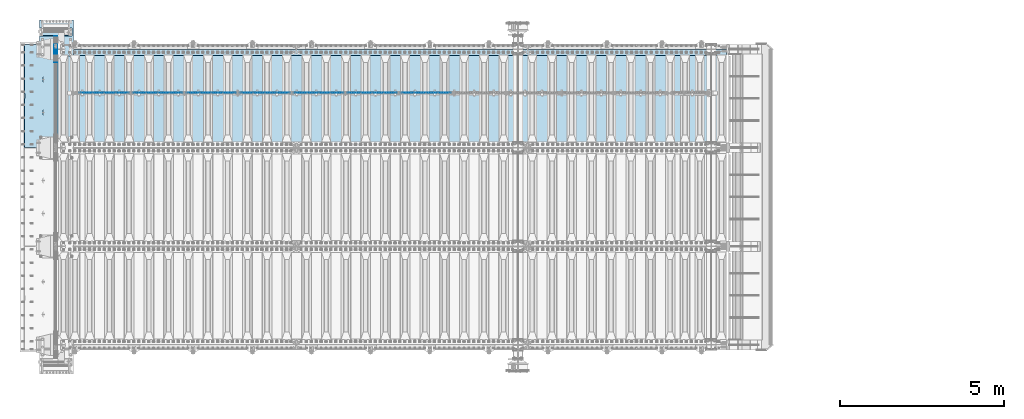
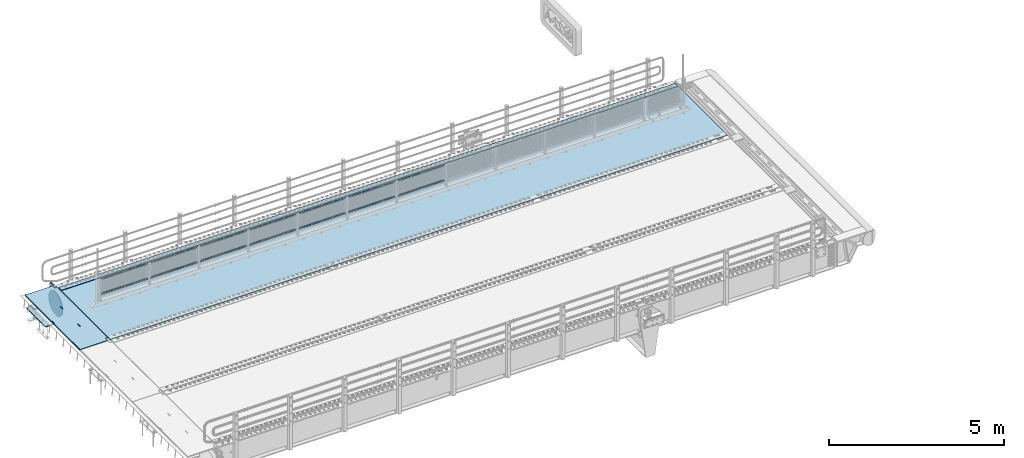
# One storey, part 212 of 270: 21 plates.
"""IFC2X3 building model written with IfcOpenShell, lengths in millimetres."""

from ifc_helpers import new_model, si_unit, frame, origin_with_axes, place, context, subcontext, project, spatial, faceted_brep, material, type_object, element, save


model = new_model("IFC2X3")

# Units and contexts
model_context = context("Model", 3, precision=1e-05, world=origin_with_axes())
body_context = subcontext(model_context, "Body", "Model", "MODEL_VIEW")
ifc_project = project(units=[si_unit("LENGTHUNIT", "METRE", prefix="MILLI"), si_unit("AREAUNIT", "SQUARE_METRE"), si_unit("VOLUMEUNIT", "CUBIC_METRE"), si_unit("MASSUNIT", "GRAM", prefix="KILO"), si_unit("TIMEUNIT", "SECOND"), si_unit("PLANEANGLEUNIT", "RADIAN"), si_unit("SOLIDANGLEUNIT", "STERADIAN"), si_unit("THERMODYNAMICTEMPERATUREUNIT", "DEGREE_CELSIUS"), si_unit("LUMINOUSINTENSITYUNIT", "LUMEN")], contexts=[model_context])

# Site, building, storey
site_placement = place(None, origin_with_axes())
site = spatial("IfcSite", under=ifc_project, at=site_placement, CompositionType="ELEMENT")
building_placement = place(site_placement, origin_with_axes())
building = spatial("IfcBuilding", under=site, at=building_placement, Name="Standard", CompositionType="ELEMENT")
storey_placement = place(building_placement, origin_with_axes())
storey = spatial("IfcBuildingStorey", under=building, at=storey_placement, Name="Undefined", CompositionType="ELEMENT", Elevation=0.0)

# Plates
ifc_material_1 = material(Name="STEEL/S355N")
plate_type_1 = type_object("IfcPlateType", PredefinedType="NOTDEFINED")
plate_1_placement = place(storey_placement, frame((-5.0037545708802, -14850.0000738707, -0.984391683369125), z_axis=(0.0, -0.999999999987744, -4.95099999993769e-06), x_axis=(-0.999999999879068, -1.00000022172504e-09, -1.55519999981193e-05)))
element("IfcPlate", 1, at=plate_1_placement, inside=storey, type_object=plate_type_1, material=ifc_material_1, context=body_context, shape_type="Brep", body=[
    faceted_brep([(14.9998601691701, 15.0, 125.000024820878), (-0.000294611402146039, -0.000806902969057388, 124.999936248681), (-0.00191941583158783, 0.000806844427335363, 3020.00000492307), (14.9966216875132, 15.0, 3020.00007976655), (999.996459960937, 5.0, 3.63797880709171e-12), (984.996459960937, 15.0, 3.63797880709171e-12), (984.996459718778, 15.0, 3145.0), (999.996459718778, 5.0, 3145.0), (984.996459961366, -15.0, 0.0), (999.996459960937, -5.0, 3.63797880709171e-12), (999.996459718778, -5.0, 3145.0), (984.996459719206, -15.0, 3145.0), (74.9997820614451, -15.0, 0.0), (74.9996421865538, -15.0000000127077, 124.999930084148), (75.0001087165527, 15.0, 125.000079754147), (75.0002485914438, 15.0, 0.0), (-0.000449375328801516, -14.9999999951864, 124.999861417793), (395.486056604085, -15.0000000067239, 2004.40983005394), (395.486056604084, 15.0, 2004.40983005394), (394.996621766798, 15.0, 2007.4999999977), (394.996621766798, -15.0000000067363, 2007.4999999977), (396.906451823501, -15.0000000066914, 2001.62214747477), (396.906451823501, 15.0, 2001.62214747477), (399.118769244497, -15.0000000066418, 1999.40983005394), (399.118769244497, 15.0, 1999.40983005394), (401.906451823781, -15.0000000065801, 1997.98943483475), (401.906451823781, 15.0, 1997.98943483474), (404.996621767569, -15.0000000065123, 1997.4999999977), (404.996621767569, 15.0, 1997.49999999769), (408.086791711164, -15.0000000064451, 1997.98943483474), (408.086791711164, 15.0, 1997.98943483474), (410.874474290229, -15.0000000063849, 1999.40983005394), (410.874474290229, 15.0, 1999.40983005394), (413.086791710883, -15.0000000063378, 2001.62214747477), (413.086791710883, 15.0, 2001.62214747477), (414.507186929871, -15.0000000063082, 2004.40983005394), (414.507186929871, 15.0, 2004.40983005394), (414.996621766684, -15.0000000062992, 2007.49999999769), (414.996621766684, 15.0, 2007.49999999769), (414.99662175677, -15.0000000063698, 2137.49999999769), (414.99662175677, 15.0, 2137.49999999769), (414.507186919485, -15.0000000063821, 2140.59016994144), (414.507186919485, 15.0, 2140.59016994144), (413.086791700069, -15.0000000064147, 2143.37785252062), (413.086791700069, 15.0, 2143.37785252061), (410.874474279073, -15.0000000064642, 2145.59016994145), (410.874474279073, 15.0, 2145.59016994144), (408.086791699787, -15.0000000065259, 2147.01056516065), (408.086791699787, 15.0, 2147.01056516065), (404.996621755999, -15.0000000065937, 2147.49999999769), (404.996621755999, 15.0, 2147.49999999769), (401.906451812295, -15.000000006661, 2147.01056516065), (401.906451812295, 15.0, 2147.01056516065), (399.118769233229, -15.0000000067211, 2145.59016994145), (399.118769233229, 15.0, 2145.59016994145), (396.906451812575, -15.0000000067683, 2143.37785252062), (396.906451812575, 15.0, 2143.37785252062), (395.486056593588, -15.0000000067978, 2140.59016994145), (395.486056593588, 15.0, 2140.59016994144), (394.996621756778, -15.0000000068068, 2137.4999999977), (394.996621756778, 15.0, 2137.4999999977), (960.486056642586, -14.9999999941054, 1504.40983005418), (960.486056642586, 15.0, 1504.40983005418), (959.996621805299, 15.0, 1507.49999999792), (959.996621805299, -14.9999999941178, 1507.49999999793), (961.906451862003, -14.9999999940729, 1501.622147475), (961.906451862003, 15.0, 1501.622147475), (964.118769282998, -14.9999999940233, 1499.40983005418), (964.118769282998, 15.0, 1499.40983005418), (966.906451862283, -14.9999999939616, 1497.98943483498), (966.906451862283, 15.0, 1497.98943483497), (969.99662180607, -14.9999999938938, 1497.49999999793), (969.99662180607, 15.0, 1497.49999999793), (973.086791749665, -14.9999999938266, 1497.98943483497), (973.086791749666, 15.0, 1497.98943483497), (975.87447432873, -14.9999999937664, 1499.40983005418), (975.87447432873, 15.0, 1499.40983005418), (978.086791749384, -14.9999999937193, 1501.622147475), (978.086791749384, 15.0, 1501.622147475), (979.507186968372, -14.9999999936897, 1504.40983005417), (979.507186968372, 15.0, 1504.40983005417), (979.996621805185, -14.9999999936807, 1507.49999999792), (979.996621805184, 15.0, 1507.49999999792), (979.996621795271, -14.9999999937513, 1637.49999999792), (979.996621795271, 15.0, 1637.49999999792), (979.507186957986, -14.9999999937636, 1640.59016994167), (979.507186957986, 15.0, 1640.59016994167), (978.08679173857, -14.9999999937962, 1643.37785252085), (978.08679173857, 15.0, 1643.37785252085), (975.874474317574, -14.9999999938457, 1645.59016994168), (975.874474317574, 15.0, 1645.59016994168), (973.086791738289, -14.9999999939074, 1647.01056516088), (973.086791738289, 15.0, 1647.01056516088), (969.9966217945, -14.9999999939752, 1647.49999999793), (969.9966217945, 15.0, 1647.49999999793), (966.906451850796, -14.9999999940425, 1647.01056516088), (966.906451850796, 15.0, 1647.01056516088), (964.118769271731, -14.9999999941026, 1645.59016994168), (964.118769271731, 15.0, 1645.59016994168), (961.906451851076, -14.9999999941498, 1643.37785252085), (961.906451851077, 15.0, 1643.37785252085), (960.486056632089, -14.9999999941793, 1640.59016994168), (960.486056632089, 15.0, 1640.59016994168), (959.996621795279, -14.9999999941883, 1637.49999999793), (959.996621795279, 15.0, 1637.49999999792), (74.9967306508662, 15.0, 3145.0), (74.9962640908673, -15.0, 3145.0), (74.9968705257564, 15.0, 3020.00007982415), (74.9964039657577, -15.0, 3019.99993015415), (-0.000460362207132192, -15.00000004538, 3019.99993008594), (395.486056670583, -15.0000000062551, 1140.59016994197), (396.90645188957, -15.0000000062256, 1143.37785252115), (399.118769310224, -15.0000000061784, 1145.59016994197), (401.90645188929, -15.0000000061183, 1147.01056516118), (404.996621832993, -15.000000006051, 1147.49999999822), (408.086791776782, -15.0000000059832, 1147.01056516118), (410.874474356068, -15.0000000059215, 1145.59016994197), (413.086791777063, -15.000000005872, 1143.37785252115), (414.507186996479, -15.0000000058394, 1140.59016994197), (414.996621833764, -15.0000000058271, 1137.49999999822), (414.996621843678, -15.0000000057565, 1007.49999999822), (414.507187006866, -15.0000000057655, 1004.40983005447), (413.086791787878, -15.0000000057951, 1001.6221474753), (410.874474367224, -15.0000000058422, 999.409830054472), (408.086791788159, -15.0000000059024, 997.989434835272), (404.996621844563, -15.0000000059696, 997.499999998225), (401.906451900776, -15.0000000060374, 997.989434835275), (399.118769321491, -15.0000000060991, 999.409830054472), (396.906451900496, -15.0000000061487, 1001.6221474753), (395.486056681079, -15.0000000061812, 1004.40983005448), (394.996621843792, -15.0000000061936, 1007.49999999823), (394.996621833772, -15.0000000062641, 1137.49999999822), (396.906451900496, 15.0, 1001.6221474753), (395.486056681079, 15.0, 1004.40983005447), (399.118769321491, 15.0, 999.409830054472), (401.906451900776, 15.0, 997.989434835272), (404.996621844563, 15.0, 997.499999998221), (408.086791788159, 15.0, 997.989434835272), (410.874474367224, 15.0, 999.409830054472), (413.086791787877, 15.0, 1001.62214747529), (414.507187006866, 15.0, 1004.40983005447), (414.996621843678, 15.0, 1007.49999999821), (414.996621833764, 15.0, 1137.49999999821), (414.507186996479, 15.0, 1140.59016994197), (413.086791777063, 15.0, 1143.37785252114), (410.874474356068, 15.0, 1145.59016994197), (408.086791776782, 15.0, 1147.01056516118), (404.996621832993, 15.0, 1147.49999999822), (401.90645188929, 15.0, 1147.01056516117), (399.118769310224, 15.0, 1145.59016994197), (396.90645188957, 15.0, 1143.37785252115), (395.486056670583, 15.0, 1140.59016994197), (394.996621833772, 15.0, 1137.49999999822), (394.996621843792, 15.0, 1007.49999999822)], [[[0, 1, 2, 3]], [[4, 5, 6, 7]], [[8, 9, 10, 11]], [[12, 13, 14, 15]], [[14, 13, 16, 1, 0]], [[17, 18, 19, 20]], [[21, 22, 18, 17]], [[23, 24, 22, 21]], [[25, 26, 24, 23]], [[27, 28, 26, 25]], [[29, 30, 28, 27]], [[31, 32, 30, 29]], [[33, 34, 32, 31]], [[35, 36, 34, 33]], [[37, 38, 36, 35]], [[39, 40, 38, 37]], [[41, 42, 40, 39]], [[43, 44, 42, 41]], [[45, 46, 44, 43]], [[47, 48, 46, 45]], [[49, 50, 48, 47]], [[51, 52, 50, 49]], [[53, 54, 52, 51]], [[55, 56, 54, 53]], [[57, 58, 56, 55]], [[59, 60, 58, 57]], [[20, 19, 60, 59]], [[61, 62, 63, 64]], [[65, 66, 62, 61]], [[67, 68, 66, 65]], [[69, 70, 68, 67]], [[71, 72, 70, 69]], [[73, 74, 72, 71]], [[75, 76, 74, 73]], [[77, 78, 76, 75]], [[79, 80, 78, 77]], [[81, 82, 80, 79]], [[83, 84, 82, 81]], [[85, 86, 84, 83]], [[87, 88, 86, 85]], [[89, 90, 88, 87]], [[91, 92, 90, 89]], [[93, 94, 92, 91]], [[95, 96, 94, 93]], [[97, 98, 96, 95]], [[99, 100, 98, 97]], [[101, 102, 100, 99]], [[103, 104, 102, 101]], [[64, 63, 104, 103]], [[9, 8, 12, 15, 5, 4]], [[10, 9, 4, 7]], [[105, 106, 11, 10, 7, 6]], [[106, 105, 107, 108]], [[109, 108, 107, 3, 2]], [[106, 108, 109, 16, 13, 12, 8, 11], [101, 99, 97, 95, 93, 91, 89, 87, 85, 83, 81, 79, 77, 75, 73, 71, 69, 67, 65, 61, 64, 103], [57, 55, 53, 51, 49, 47, 45, 43, 41, 39, 37, 35, 33, 31, 29, 27, 25, 23, 21, 17, 20, 59], [110, 111, 112, 113, 114, 115, 116, 117, 118, 119, 120, 121, 122, 123, 124, 125, 126, 127, 128, 129, 130, 131]], [[128, 132, 133, 129]], [[127, 134, 132, 128]], [[126, 135, 134, 127]], [[125, 136, 135, 126]], [[124, 137, 136, 125]], [[123, 138, 137, 124]], [[122, 139, 138, 123]], [[121, 140, 139, 122]], [[120, 141, 140, 121]], [[119, 142, 141, 120]], [[118, 143, 142, 119]], [[117, 144, 143, 118]], [[116, 145, 144, 117]], [[115, 146, 145, 116]], [[114, 147, 146, 115]], [[113, 148, 147, 114]], [[112, 149, 148, 113]], [[111, 150, 149, 112]], [[110, 151, 150, 111]], [[131, 152, 151, 110]], [[130, 153, 152, 131]], [[129, 133, 153, 130]], [[107, 105, 6, 5, 15, 14, 0, 3], [132, 134, 135, 136, 137, 138, 139, 140, 141, 142, 143, 144, 145, 146, 147, 148, 149, 150, 151, 152, 153, 133], [22, 24, 26, 28, 30, 32, 34, 36, 38, 40, 42, 44, 46, 48, 50, 52, 54, 56, 58, 60, 19, 18], [66, 68, 70, 72, 74, 76, 78, 80, 82, 84, 86, 88, 90, 92, 94, 96, 98, 100, 102, 104, 63, 62]], [[16, 109, 2, 1]]]),
])
ifc_material_2 = material()
plate_type_2 = type_object("IfcPlateType", PredefinedType="NOTDEFINED")
plate_2_placement = place(storey_placement, frame((454.999999694883, -14354.9999983054, -813.000000000004), z_axis=(0.0, -1.0, 0.0), x_axis=(-1.0, 0.0, 0.0)))
element("IfcPlate", 2, at=plate_2_placement, inside=storey, type_object=plate_type_2, material=ifc_material_2, context=body_context, shape_type="Brep", body=[
    faceted_brep([(0.0, 0.0, 235.0), (0.0, -15.0, 220.0), (979.0, -15.0, 220.0), (979.0, 0.0, 235.0), (0.0, 15.0, 235.0), (0.0, 15.0, 0.0), (0.0, -15.0, 0.0), (979.0, 15.0, 235.0), (979.0, -15.0, 0.0), (979.0, 15.0, 0.0)], [[[0, 1, 2, 3]], [[4, 5, 6, 1, 0]], [[7, 4, 0, 3]], [[8, 9, 7, 3, 2]], [[8, 6, 5, 9]], [[7, 9, 5, 4]], [[6, 8, 2, 1]]]),
])
plate_type_3 = type_object("IfcPlateType", PredefinedType="NOTDEFINED")
plate_3_placement = place(storey_placement, frame((-524.000000550228, -14109.9999992844, -1053.0), z_axis=(1.0, 0.0, 0.0), x_axis=(0.0, -1.0, 0.0)))
element("IfcPlate", 3, at=plate_3_placement, inside=storey, type_object=plate_type_3, material=ifc_material_2, context=body_context, shape_type="Brep", body=[
    faceted_brep([(0.0, -15.0, 0.0), (2.93249286187347e-06, -15.0, 1025.0), (2.93249286187347e-06, 15.0, 1025.0), (0.0, 15.0, 0.0), (1100.0, -15.0, 1025.0), (1100.0, 15.0, 1025.0), (1100.0, -15.0, -1.9554136088118e-11), (1100.0, 15.0, -1.9554136088118e-11)], [[[0, 1, 2, 3]], [[1, 4, 5, 2]], [[4, 6, 7, 5]], [[6, 0, 3, 7]], [[5, 7, 3, 2]], [[6, 4, 1, 0]]]),
])
ifc_material_3 = material(Name="Misc_Undefined")
plate_type_4 = type_object("IfcPlateType", PredefinedType="NOTDEFINED")
plate_4_placement = place(storey_placement, frame((10472.5050117304, -16329.5, 351.520303374641), z_axis=(0.0, 0.0, 1.0), x_axis=(1.0, 0.0, 0.0)))
element("IfcPlate", 4, at=plate_4_placement, inside=storey, type_object=plate_type_4, material=ifc_material_3, context=body_context, shape_type="Brep", body=[
    faceted_brep([(0.0, -1.5, 0.0), (35.0002975463867, -1.5, 34.9996948242188), (35.0002975463867, 1.5, 34.9996948242188), (0.0, 1.5, 0.0), (1490.99035644531, -1.5, 34.9999923706055), (1490.99035644531, 1.5, 34.9999923706055), (1525.98999023438, -1.5, 2.81374923361e-11), (1525.98999023438, 1.5, 2.81374923361e-11)], [[[0, 1, 2, 3]], [[1, 4, 5, 2]], [[4, 6, 7, 5]], [[6, 0, 3, 7]], [[5, 7, 3, 2]], [[6, 4, 1, 0]]]),
])
plate_5_placement = place(storey_placement, frame((11998.5000001876, -16329.5, 914.520000175701), z_axis=(-0.707103624179499, 0.0, 0.707109938179501), x_axis=(-0.707109938179488, 0.0, -0.707103624179512)))
element("IfcPlate", 5, at=plate_5_placement, inside=storey, type_object=plate_type_4, material=ifc_material_3, context=body_context, shape_type="Brep", body=[
    faceted_brep([(0.0, -1.5, 0.0), (1079.04980468752, -1.5, 1079.04028320313), (1079.04980468752, 1.5, 1079.04028320313), (0.0, 1.5, 0.0), (1079.04272460939, -1.5, 1029.53576660156), (1079.04272460939, 1.5, 1029.53576660156), (49.4976959228497, -1.5, -7.27595761418343e-12), (49.4976959228497, 1.5, -7.27595761418343e-12)], [[[0, 1, 2, 3]], [[1, 4, 5, 2]], [[4, 6, 7, 5]], [[6, 0, 3, 7]], [[5, 7, 3, 2]], [[6, 4, 1, 0]]]),
])
plate_6_placement = place(storey_placement, frame((8839.50501173036, -16329.5, 351.520303374641), z_axis=(0.0, 0.0, 1.0), x_axis=(1.0, 0.0, 0.0)))
element("IfcPlate", 6, at=plate_6_placement, inside=storey, type_object=plate_type_4, material=ifc_material_3, context=body_context, shape_type="Brep", body=[
    faceted_brep([(0.0, -1.5, 0.0), (35.0002975463867, -1.5, 34.9996948242188), (35.0002975463867, 1.5, 34.9996948242188), (0.0, 1.5, 0.0), (1490.99035644531, -1.5, 34.9999923706055), (1490.99035644531, 1.5, 34.9999923706055), (1525.98999023438, -1.5, 2.81374923361e-11), (1525.98999023438, 1.5, 2.81374923361e-11)], [[[0, 1, 2, 3]], [[1, 4, 5, 2]], [[4, 6, 7, 5]], [[6, 0, 3, 7]], [[5, 7, 3, 2]], [[6, 4, 1, 0]]]),
])
plate_7_placement = place(storey_placement, frame((10365.5000001876, -16329.5, 914.520000175701), z_axis=(-0.707103624179499, 0.0, 0.707109938179501), x_axis=(-0.707109938179488, 0.0, -0.707103624179512)))
element("IfcPlate", 7, at=plate_7_placement, inside=storey, type_object=plate_type_4, material=ifc_material_3, context=body_context, shape_type="Brep", body=[
    faceted_brep([(0.0, -1.5, 0.0), (1079.04980468752, -1.5, 1079.04028320313), (1079.04980468752, 1.5, 1079.04028320313), (0.0, 1.5, 0.0), (1079.04272460939, -1.5, 1029.53576660156), (1079.04272460939, 1.5, 1029.53576660156), (49.4976959228497, -1.5, -7.27595761418343e-12), (49.4976959228497, 1.5, -7.27595761418343e-12)], [[[0, 1, 2, 3]], [[1, 4, 5, 2]], [[4, 6, 7, 5]], [[6, 0, 3, 7]], [[5, 7, 3, 2]], [[6, 4, 1, 0]]]),
])
plate_8_placement = place(storey_placement, frame((7206.50501173036, -16329.5, 351.520303374641), z_axis=(0.0, 0.0, 1.0), x_axis=(1.0, 0.0, 0.0)))
element("IfcPlate", 8, at=plate_8_placement, inside=storey, type_object=plate_type_4, material=ifc_material_3, context=body_context, shape_type="Brep", body=[
    faceted_brep([(0.0, -1.5, 0.0), (35.0002975463867, -1.5, 34.9996948242188), (35.0002975463867, 1.5, 34.9996948242188), (0.0, 1.5, 0.0), (1490.99035644531, -1.5, 34.9999923706055), (1490.99035644531, 1.5, 34.9999923706055), (1525.98999023438, -1.5, 2.81374923361e-11), (1525.98999023438, 1.5, 2.81374923361e-11)], [[[0, 1, 2, 3]], [[1, 4, 5, 2]], [[4, 6, 7, 5]], [[6, 0, 3, 7]], [[5, 7, 3, 2]], [[6, 4, 1, 0]]]),
])
plate_9_placement = place(storey_placement, frame((8732.5000001876, -16329.5, 914.520000175701), z_axis=(-0.707103624179499, 0.0, 0.707109938179501), x_axis=(-0.707109938179488, 0.0, -0.707103624179512)))
element("IfcPlate", 9, at=plate_9_placement, inside=storey, type_object=plate_type_4, material=ifc_material_3, context=body_context, shape_type="Brep", body=[
    faceted_brep([(0.0, -1.5, 0.0), (1079.04980468752, -1.5, 1079.04028320313), (1079.04980468752, 1.5, 1079.04028320313), (0.0, 1.5, 0.0), (1079.04272460939, -1.5, 1029.53576660156), (1079.04272460939, 1.5, 1029.53576660156), (49.4976959228497, -1.5, -7.27595761418343e-12), (49.4976959228497, 1.5, -7.27595761418343e-12)], [[[0, 1, 2, 3]], [[1, 4, 5, 2]], [[4, 6, 7, 5]], [[6, 0, 3, 7]], [[5, 7, 3, 2]], [[6, 4, 1, 0]]]),
])
plate_10_placement = place(storey_placement, frame((5573.50501173036, -16329.5, 351.520303374641), z_axis=(0.0, 0.0, 1.0), x_axis=(1.0, 0.0, 0.0)))
element("IfcPlate", 10, at=plate_10_placement, inside=storey, type_object=plate_type_4, material=ifc_material_3, context=body_context, shape_type="Brep", body=[
    faceted_brep([(0.0, -1.5, 0.0), (35.0002975463867, -1.5, 34.9996948242188), (35.0002975463867, 1.5, 34.9996948242188), (0.0, 1.5, 0.0), (1490.99035644531, -1.5, 34.9999923706055), (1490.99035644531, 1.5, 34.9999923706055), (1525.98999023438, -1.5, 2.81374923361e-11), (1525.98999023438, 1.5, 2.81374923361e-11)], [[[0, 1, 2, 3]], [[1, 4, 5, 2]], [[4, 6, 7, 5]], [[6, 0, 3, 7]], [[5, 7, 3, 2]], [[6, 4, 1, 0]]]),
])
plate_11_placement = place(storey_placement, frame((7099.5000001876, -16329.5, 914.520000175701), z_axis=(-0.707103624179499, 0.0, 0.707109938179501), x_axis=(-0.707109938179488, 0.0, -0.707103624179512)))
element("IfcPlate", 11, at=plate_11_placement, inside=storey, type_object=plate_type_4, material=ifc_material_3, context=body_context, shape_type="Brep", body=[
    faceted_brep([(0.0, -1.5, 0.0), (1079.04980468752, -1.5, 1079.04028320313), (1079.04980468752, 1.5, 1079.04028320313), (0.0, 1.5, 0.0), (1079.04272460939, -1.5, 1029.53576660156), (1079.04272460939, 1.5, 1029.53576660156), (49.4976959228497, -1.5, -7.27595761418343e-12), (49.4976959228497, 1.5, -7.27595761418343e-12)], [[[0, 1, 2, 3]], [[1, 4, 5, 2]], [[4, 6, 7, 5]], [[6, 0, 3, 7]], [[5, 7, 3, 2]], [[6, 4, 1, 0]]]),
])
plate_12_placement = place(storey_placement, frame((3940.50501173036, -16329.5, 351.520303374641), z_axis=(0.0, 0.0, 1.0), x_axis=(1.0, 0.0, 0.0)))
element("IfcPlate", 12, at=plate_12_placement, inside=storey, type_object=plate_type_4, material=ifc_material_3, context=body_context, shape_type="Brep", body=[
    faceted_brep([(0.0, -1.5, 0.0), (35.0002975463867, -1.5, 34.9996948242188), (35.0002975463867, 1.5, 34.9996948242188), (0.0, 1.5, 0.0), (1490.99035644531, -1.5, 34.9999923706055), (1490.99035644531, 1.5, 34.9999923706055), (1525.98999023438, -1.5, 2.81374923361e-11), (1525.98999023438, 1.5, 2.81374923361e-11)], [[[0, 1, 2, 3]], [[1, 4, 5, 2]], [[4, 6, 7, 5]], [[6, 0, 3, 7]], [[5, 7, 3, 2]], [[6, 4, 1, 0]]]),
])
plate_13_placement = place(storey_placement, frame((5466.5000001876, -16329.5, 914.520000175701), z_axis=(-0.707103624179499, 0.0, 0.707109938179501), x_axis=(-0.707109938179488, 0.0, -0.707103624179512)))
element("IfcPlate", 13, at=plate_13_placement, inside=storey, type_object=plate_type_4, material=ifc_material_3, context=body_context, shape_type="Brep", body=[
    faceted_brep([(0.0, -1.5, 0.0), (1079.04980468752, -1.5, 1079.04028320313), (1079.04980468752, 1.5, 1079.04028320313), (0.0, 1.5, 0.0), (1079.04272460939, -1.5, 1029.53576660156), (1079.04272460939, 1.5, 1029.53576660156), (49.4976959228497, -1.5, -7.27595761418343e-12), (49.4976959228497, 1.5, -7.27595761418343e-12)], [[[0, 1, 2, 3]], [[1, 4, 5, 2]], [[4, 6, 7, 5]], [[6, 0, 3, 7]], [[5, 7, 3, 2]], [[6, 4, 1, 0]]]),
])
plate_14_placement = place(storey_placement, frame((2307.50501173036, -16329.5, 351.520303374641), z_axis=(0.0, 0.0, 1.0), x_axis=(1.0, 0.0, 0.0)))
element("IfcPlate", 14, at=plate_14_placement, inside=storey, type_object=plate_type_4, material=ifc_material_3, context=body_context, shape_type="Brep", body=[
    faceted_brep([(0.0, -1.5, 0.0), (35.0002975463867, -1.5, 34.9996948242188), (35.0002975463867, 1.5, 34.9996948242188), (0.0, 1.5, 0.0), (1490.99035644531, -1.5, 34.9999923706055), (1490.99035644531, 1.5, 34.9999923706055), (1525.98999023438, -1.5, 2.81374923361e-11), (1525.98999023438, 1.5, 2.81374923361e-11)], [[[0, 1, 2, 3]], [[1, 4, 5, 2]], [[4, 6, 7, 5]], [[6, 0, 3, 7]], [[5, 7, 3, 2]], [[6, 4, 1, 0]]]),
])
plate_15_placement = place(storey_placement, frame((3833.5000001876, -16329.5, 914.520000175701), z_axis=(-0.707103624179499, 0.0, 0.707109938179501), x_axis=(-0.707109938179488, 0.0, -0.707103624179512)))
element("IfcPlate", 15, at=plate_15_placement, inside=storey, type_object=plate_type_4, material=ifc_material_3, context=body_context, shape_type="Brep", body=[
    faceted_brep([(0.0, -1.5, 0.0), (1079.04980468752, -1.5, 1079.04028320313), (1079.04980468752, 1.5, 1079.04028320313), (0.0, 1.5, 0.0), (1079.04272460939, -1.5, 1029.53576660156), (1079.04272460939, 1.5, 1029.53576660156), (49.4976959228497, -1.5, -7.27595761418343e-12), (49.4976959228497, 1.5, -7.27595761418343e-12)], [[[0, 1, 2, 3]], [[1, 4, 5, 2]], [[4, 6, 7, 5]], [[6, 0, 3, 7]], [[5, 7, 3, 2]], [[6, 4, 1, 0]]]),
])
plate_16_placement = place(storey_placement, frame((674.505011730362, -16329.5, 351.520303374641), z_axis=(0.0, 0.0, 1.0), x_axis=(1.0, 0.0, 0.0)))
element("IfcPlate", 16, at=plate_16_placement, inside=storey, type_object=plate_type_4, material=ifc_material_3, context=body_context, shape_type="Brep", body=[
    faceted_brep([(0.0, -1.5, 0.0), (35.0002975463867, -1.5, 34.9996948242188), (35.0002975463867, 1.5, 34.9996948242188), (0.0, 1.5, 0.0), (1490.99035644531, -1.5, 34.9999923706055), (1490.99035644531, 1.5, 34.9999923706055), (1525.98999023438, -1.5, 2.81374923361e-11), (1525.98999023438, 1.5, 2.81374923361e-11)], [[[0, 1, 2, 3]], [[1, 4, 5, 2]], [[4, 6, 7, 5]], [[6, 0, 3, 7]], [[5, 7, 3, 2]], [[6, 4, 1, 0]]]),
])
plate_17_placement = place(storey_placement, frame((2200.5000001876, -16329.5, 914.520000175701), z_axis=(-0.707103624179499, 0.0, 0.707109938179501), x_axis=(-0.707109938179488, 0.0, -0.707103624179512)))
element("IfcPlate", 17, at=plate_17_placement, inside=storey, type_object=plate_type_4, material=ifc_material_3, context=body_context, shape_type="Brep", body=[
    faceted_brep([(0.0, -1.5, 0.0), (1079.04980468752, -1.5, 1079.04028320313), (1079.04980468752, 1.5, 1079.04028320313), (0.0, 1.5, 0.0), (1079.04272460939, -1.5, 1029.53576660156), (1079.04272460939, 1.5, 1029.53576660156), (49.4976959228497, -1.5, -7.27595761418343e-12), (49.4976959228497, 1.5, -7.27595761418343e-12)], [[[0, 1, 2, 3]], [[1, 4, 5, 2]], [[4, 6, 7, 5]], [[6, 0, 3, 7]], [[5, 7, 3, 2]], [[6, 4, 1, 0]]]),
])
plate_type_5 = type_object("IfcPlateType", PredefinedType="NOTDEFINED")
plate_18_placement = place(storey_placement, frame((-4.99999999999636, -15400.0, -20.0), z_axis=(0.0, 1.0, 0.0), x_axis=(0.0, 0.0, -1.0)))
element("IfcPlate", 18, at=plate_18_placement, inside=storey, type_object=plate_type_5, material=ifc_material_1, context=body_context, shape_type="Brep", body=[
    faceted_brep([(855.0, -15.0, 572.963114671544), (855.0, 15.0, 572.963114671544), (849.182410261294, 15.0, 585.889268817533), (849.182410261294, -15.0, 585.889268817533), (824.193546357474, 15.0, 627.225898692486), (824.193546357474, -15.0, 627.225898692486), (794.404299268454, 15.0, 665.249063296342), (794.404299268454, -15.0, 665.249063296342), (760.249063296334, 15.0, 699.404299268463), (760.249063296334, -15.0, 699.404299268463), (722.22589869248, 15.0, 729.193546357488), (722.22589869248, -15.0, 729.193546357488), (680.889268817528, 15.0, 754.18241026131), (680.889268817528, -15.0, 754.18241026131), (636.841954817037, 15.0, 774.006497074191), (636.841954817037, -15.0, 774.006497074191), (590.726265715048, 15.0, 788.376726970451), (590.726265715048, -15.0, 788.376726970451), (543.214672102156, 15.0, 797.083549639254), (543.214672102156, -15.0, 797.083549639254), (495.0, -15.0, 800.000000000029), (495.0, 15.0, 800.0), (494.999999999412, -15.0, 0.0), (494.999999999412, 15.0, 0.0), (543.214672102129, 15.0, 2.91645036080809), (543.214672102129, -15.0, 2.91645036080809), (590.726265715023, 15.0, 11.6232730296069), (590.726265715023, -15.0, 11.6232730296069), (636.841954817014, 15.0, 25.9935029258631), (636.841954817014, -15.0, 25.9935029258631), (680.889268817507, 15.0, 45.8175897387446), (680.889268817507, -15.0, 45.8175897387446), (722.225898692462, 15.0, 70.8064536425663), (722.225898692462, -15.0, 70.8064536425663), (760.249063296318, 15.0, 100.595700731588), (760.249063296318, -15.0, 100.595700731588), (794.404299268441, 15.0, 134.750936703713), (794.404299268441, -15.0, 134.750936703713), (824.193546357463, 15.0, 172.774101307568), (824.193546357463, -15.0, 172.774101307568), (849.182410261284, 15.0, 214.110731182522), (849.182410261284, -15.0, 214.110731182522), (855.0, -15.0, 227.036885328536), (855.0, 15.0, 227.036885328536), (0.0, -15.0, 0.0), (0.0, 15.0, 0.0), (0.0, 15.0, 800.0), (0.0, -15.0, 800.0)], [[[0, 1, 2, 3]], [[3, 2, 4, 5]], [[5, 4, 6, 7]], [[7, 6, 8, 9]], [[9, 8, 10, 11]], [[11, 10, 12, 13]], [[13, 12, 14, 15]], [[15, 14, 16, 17]], [[17, 16, 18, 19]], [[20, 19, 18, 21]], [[22, 23, 24, 25]], [[25, 24, 26, 27]], [[27, 26, 28, 29]], [[29, 28, 30, 31]], [[31, 30, 32, 33]], [[33, 32, 34, 35]], [[35, 34, 36, 37]], [[37, 36, 38, 39]], [[39, 38, 40, 41]], [[42, 41, 40, 43]], [[42, 43, 1, 0]], [[44, 45, 23, 22]], [[16, 14, 12, 10, 8, 6, 4, 2, 1, 43, 40, 38, 36, 34, 32, 30, 28, 26, 24, 23, 45, 46, 21, 18]], [[44, 47, 46, 45]], [[46, 47, 20, 21]], [[47, 44, 22, 25, 27, 29, 31, 33, 35, 37, 39, 41, 42, 0, 3, 5, 7, 9, 11, 13, 15, 17, 19, 20]]]),
])
ifc_material_4 = material(Name="STEEL/S235JR")
plate_type_6 = type_object("IfcPlateType", PredefinedType="NOTDEFINED")
plate_19_placement = place(storey_placement, frame((20380.0, -15185.0, 20.0), z_axis=(-1.0, 0.0, 0.0), x_axis=(0.0, 1.0, 0.0)))
element("IfcPlate", 19, at=plate_19_placement, inside=storey, type_object=plate_type_6, material=ifc_material_4, context=body_context, shape_type="Brep", body=[
    faceted_brep([(0.0, -6.0, 0.0), (0.0, -6.0, 20360.0), (0.0, 6.0, 20360.0), (0.0, 6.0, 0.0), (170.0, -6.0, 20360.0), (170.0, 6.0, 20360.0), (170.0, -6.0, 0.0), (170.0, 6.0, 0.0)], [[[0, 1, 2, 3]], [[1, 4, 5, 2]], [[4, 6, 7, 5]], [[6, 0, 3, 7]], [[5, 7, 3, 2]], [[6, 4, 1, 0]]]),
])
plate_type_7 = type_object("IfcPlateType", PredefinedType="NOTDEFINED")
plate_20_placement = place(storey_placement, frame((10.0, -15005.0, 7.0), z_axis=(1.0, 0.0, 0.0), x_axis=(0.0, -1.0, 0.0)))
element("IfcPlate", 20, at=plate_20_placement, inside=storey, type_object=plate_type_7, material=ifc_material_1, context=body_context, shape_type="Brep", body=[
    faceted_brep([(0.0, -7.0, 0.0), (-2.96859070658684e-09, -7.0, 20380.0), (-2.96859070658684e-09, 7.0, 20380.0), (0.0, 7.0, 0.0), (2990.0, -7.0, 20380.0), (2990.0, 7.0, 20380.0), (2990.0, -7.0, 0.0), (2990.0, 7.0, 0.0)], [[[0, 1, 2, 3]], [[1, 4, 5, 2]], [[4, 6, 7, 5]], [[6, 0, 3, 7]], [[5, 7, 3, 2]], [[6, 4, 1, 0]]]),
])
plate_type_8 = type_object("IfcPlateType", PredefinedType="NOTDEFINED")
plate_21_placement = place(storey_placement, frame((-62.5000000000001, -14600.0, -114.999999999998), z_axis=(0.0, 0.0, -1.0), x_axis=(0.0, -1.0, 0.0)))
element("IfcPlate", 21, at=plate_21_placement, inside=storey, type_object=plate_type_8, material=ifc_material_1, context=body_context, shape_type="Brep", body=[
    faceted_brep([(0.0, -12.5, 400.0), (2.91645036077898, -12.5, 448.214672102129), (2.91645036077898, 12.5, 448.214672102129), (0.0, 12.5, 400.0), (11.6232730295797, -12.5, 495.726265715023), (11.6232730295797, 12.5, 495.726265715023), (25.993502925834, -12.5, 541.841954817014), (25.993502925834, 12.5, 541.841954817014), (45.8175897387155, -12.5, 585.889268817507), (45.8175897387155, 12.5, 585.889268817507), (70.8064536425372, -12.5, 627.225898692462), (70.8064536425372, 12.5, 627.225898692462), (100.595700731559, -12.5, 665.249063296318), (100.595700731559, 12.5, 665.249063296318), (134.750936703682, -12.5, 699.40429926844), (134.750936703682, 12.5, 699.40429926844), (172.774101307537, -12.5, 729.193546357462), (172.774101307537, 12.5, 729.193546357462), (214.110731182493, -12.5, 754.182410261284), (214.110731182493, 12.5, 754.182410261284), (258.158045182985, -12.5, 774.006497074166), (258.158045182985, 12.5, 774.006497074166), (304.273734284976, -12.5, 788.376726970421), (304.273734284976, 12.5, 788.376726970421), (351.785327897871, -12.5, 797.083549639221), (351.785327897871, 12.5, 797.083549639221), (400.0, -12.5, 800.0), (400.0, 12.5, 800.0), (448.214672102129, -12.5, 797.083549639222), (448.214672102129, 12.5, 797.083549639222), (495.726265715022, -12.5, 788.376726970421), (495.726265715022, 12.5, 788.376726970421), (541.841954817013, -12.5, 774.006497074166), (541.841954817013, 12.5, 774.006497074166), (585.889268817507, -12.5, 754.182410261284), (585.889268817507, 12.5, 754.182410261284), (627.225898692463, -12.5, 729.193546357463), (627.225898692463, 12.5, 729.193546357463), (665.249063296318, -12.5, 699.404299268441), (665.249063296318, 12.5, 699.404299268441), (699.404299268441, -12.5, 665.249063296318), (699.404299268441, 12.5, 665.249063296318), (729.193546357463, -12.5, 627.225898692462), (729.193546357463, 12.5, 627.225898692462), (754.182410261285, -12.5, 585.889268817507), (754.182410261285, 12.5, 585.889268817507), (774.006497074166, -12.5, 541.841954817014), (774.006497074166, 12.5, 541.841954817014), (788.37672697042, -12.5, 495.726265715023), (788.37672697042, 12.5, 495.726265715023), (797.083549639221, -12.5, 448.214672102129), (797.083549639221, 12.5, 448.214672102129), (800.0, -12.5, 400.0), (800.0, 12.5, 400.0), (797.083549639221, -12.5, 351.785327897871), (797.083549639221, 12.5, 351.785327897871), (788.37672697042, -12.5, 304.273734284977), (788.37672697042, 12.5, 304.273734284977), (774.006497074166, -12.5, 258.158045182986), (774.006497074166, 12.5, 258.158045182986), (754.182410261285, -12.5, 214.110731182493), (754.182410261285, 12.5, 214.110731182493), (729.193546357463, -12.5, 172.774101307538), (729.193546357463, 12.5, 172.774101307538), (699.404299268441, -12.5, 134.750936703682), (699.404299268441, 12.5, 134.750936703682), (665.249063296318, -12.5, 100.59570073156), (665.249063296318, 12.5, 100.59570073156), (627.225898692463, -12.5, 70.8064536425375), (627.225898692463, 12.5, 70.8064536425375), (585.889268817507, -12.5, 45.817589738716), (585.889268817507, 12.5, 45.817589738716), (541.841954817015, -12.5, 25.9935029258342), (541.841954817015, 12.5, 25.9935029258342), (495.726265715024, -12.5, 11.6232730295793), (495.726265715024, 12.5, 11.6232730295793), (448.214672102129, -12.5, 2.91645036077847), (448.214672102129, 12.5, 2.91645036077847), (400.0, -12.5, -5.6843418860808e-14), (400.0, 12.5, -5.6843418860808e-14), (351.785327897871, -12.5, 2.91645036077836), (351.785327897871, 12.5, 2.91645036077836), (304.273734284976, -12.5, 11.6232730295792), (304.273734284976, 12.5, 11.6232730295792), (258.158045182985, -12.5, 25.993502925834), (258.158045182985, 12.5, 25.993502925834), (214.110731182493, -12.5, 45.817589738716), (214.110731182493, 12.5, 45.817589738716), (172.774101307537, -12.5, 70.8064536425374), (172.774101307537, 12.5, 70.8064536425374), (134.750936703682, -12.5, 100.595700731559), (134.750936703682, 12.5, 100.595700731559), (100.595700731559, -12.5, 134.750936703682), (100.595700731559, 12.5, 134.750936703682), (70.8064536425372, -12.5, 172.774101307538), (70.8064536425372, 12.5, 172.774101307538), (45.8175897387155, -12.5, 214.110731182492), (45.8175897387155, 12.5, 214.110731182492), (25.993502925834, -12.5, 258.158045182986), (25.993502925834, 12.5, 258.158045182986), (11.6232730295797, -12.5, 304.273734284977), (11.6232730295797, 12.5, 304.273734284977), (2.91645036077898, -12.5, 351.785327897871), (2.91645036077898, 12.5, 351.785327897871)], [[[0, 1, 2, 3]], [[1, 4, 5, 2]], [[4, 6, 7, 5]], [[6, 8, 9, 7]], [[8, 10, 11, 9]], [[10, 12, 13, 11]], [[12, 14, 15, 13]], [[14, 16, 17, 15]], [[16, 18, 19, 17]], [[18, 20, 21, 19]], [[20, 22, 23, 21]], [[22, 24, 25, 23]], [[24, 26, 27, 25]], [[26, 28, 29, 27]], [[28, 30, 31, 29]], [[30, 32, 33, 31]], [[32, 34, 35, 33]], [[34, 36, 37, 35]], [[36, 38, 39, 37]], [[38, 40, 41, 39]], [[40, 42, 43, 41]], [[42, 44, 45, 43]], [[44, 46, 47, 45]], [[46, 48, 49, 47]], [[48, 50, 51, 49]], [[50, 52, 53, 51]], [[52, 54, 55, 53]], [[54, 56, 57, 55]], [[56, 58, 59, 57]], [[58, 60, 61, 59]], [[60, 62, 63, 61]], [[62, 64, 65, 63]], [[64, 66, 67, 65]], [[66, 68, 69, 67]], [[68, 70, 71, 69]], [[70, 72, 73, 71]], [[72, 74, 75, 73]], [[74, 76, 77, 75]], [[76, 78, 79, 77]], [[78, 80, 81, 79]], [[80, 82, 83, 81]], [[82, 84, 85, 83]], [[84, 86, 87, 85]], [[86, 88, 89, 87]], [[88, 90, 91, 89]], [[90, 92, 93, 91]], [[92, 94, 95, 93]], [[94, 96, 97, 95]], [[96, 98, 99, 97]], [[98, 100, 101, 99]], [[100, 102, 103, 101]], [[102, 0, 3, 103]], [[5, 7, 9, 11, 13, 15, 17, 19, 21, 23, 25, 27, 29, 31, 33, 35, 37, 39, 41, 43, 45, 47, 49, 51, 53, 55, 57, 59, 61, 63, 65, 67, 69, 71, 73, 75, 77, 79, 81, 83, 85, 87, 89, 91, 93, 95, 97, 99, 101, 103, 3, 2]], [[102, 100, 98, 96, 94, 92, 90, 88, 86, 84, 82, 80, 78, 76, 74, 72, 70, 68, 66, 64, 62, 60, 58, 56, 54, 52, 50, 48, 46, 44, 42, 40, 38, 36, 34, 32, 30, 28, 26, 24, 22, 20, 18, 16, 14, 12, 10, 8, 6, 4, 1, 0]]]),
])

save(model, "model.ifc")
